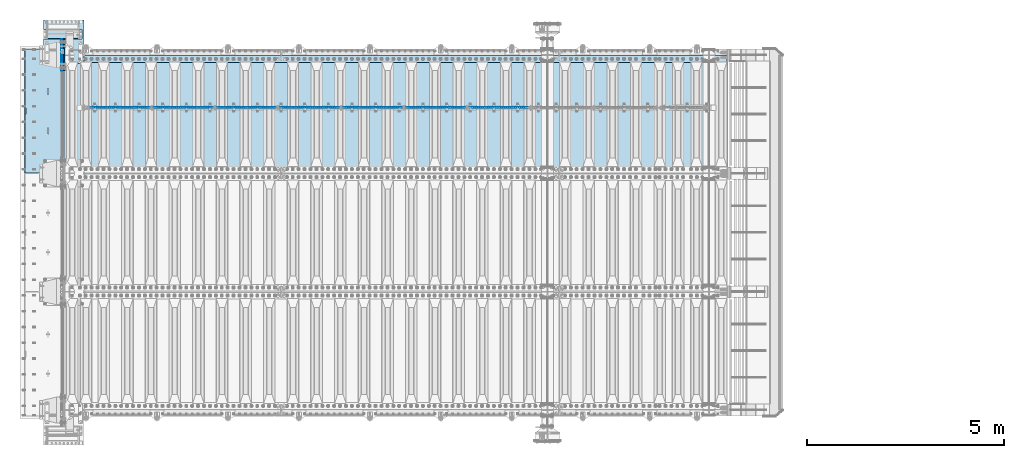
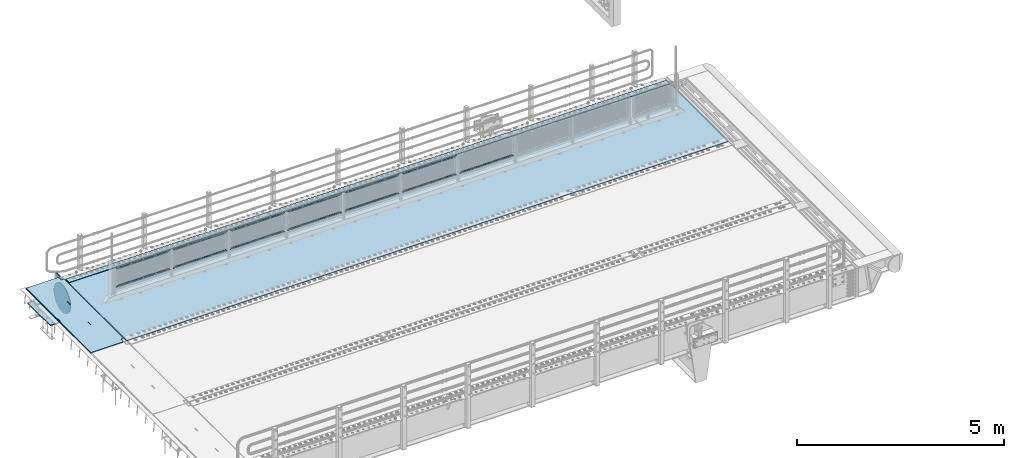
# One storey, part 194 of 247: 20 plates.
"""IFC2X3 building model written with IfcOpenShell, lengths in millimetres."""

from ifc_helpers import new_model, si_unit, frame, origin_with_axes, place, context, subcontext, project, spatial, faceted_brep, material, type_object, element, save


model = new_model("IFC2X3")

# Units and contexts
model_context = context("Model", 3, precision=1e-05, world=origin_with_axes())
body_context = subcontext(model_context, "Body", "Model", "MODEL_VIEW")
ifc_project = project(units=[si_unit("LENGTHUNIT", "METRE", prefix="MILLI"), si_unit("AREAUNIT", "SQUARE_METRE"), si_unit("VOLUMEUNIT", "CUBIC_METRE"), si_unit("MASSUNIT", "GRAM", prefix="KILO"), si_unit("TIMEUNIT", "SECOND"), si_unit("PLANEANGLEUNIT", "RADIAN"), si_unit("SOLIDANGLEUNIT", "STERADIAN"), si_unit("THERMODYNAMICTEMPERATUREUNIT", "DEGREE_CELSIUS"), si_unit("LUMINOUSINTENSITYUNIT", "LUMEN")], contexts=[model_context])

# Site, building, storey
site_placement = place(None, origin_with_axes())
site = spatial("IfcSite", under=ifc_project, at=site_placement, CompositionType="ELEMENT")
building_placement = place(site_placement, origin_with_axes())
building = spatial("IfcBuilding", under=site, at=building_placement, Name="Standard", CompositionType="ELEMENT")
storey_placement = place(building_placement, origin_with_axes())
storey = spatial("IfcBuildingStorey", under=building, at=storey_placement, Name="Undefined", CompositionType="ELEMENT", Elevation=0.0)

# Plates
ifc_material_1 = material(Name="STEEL/S355N")
plate_type_1 = type_object("IfcPlateType", PredefinedType="NOTDEFINED")
plate_1_placement = place(storey_placement, frame((-5.0037545708802, 9149.99992612933, -0.984391683369127), z_axis=(1.00000000012752e-09, -0.999999999987744, -4.95099999993936e-06), x_axis=(-0.999999999879068, -1.00000022172504e-09, -1.55519999981193e-05)))
element("IfcPlate", 1, at=plate_1_placement, inside=storey, type_object=plate_type_1, material=ifc_material_1, context=body_context, shape_type="Brep", body=[
    faceted_brep([(14.9998601691701, 15.0, 125.000024820866), (-0.000294611402138933, -0.00080690296905217, 124.999936248667), (-0.00191941583158695, 0.000806844427329922, 3020.00000492307), (14.9966216875132, 15.0, 3020.00007976655), (999.996459960937, 5.0, 1.36424205265939e-12), (984.996459960937, 15.0, 1.36424205265939e-12), (984.996459718778, 15.0, 3145.0), (999.996459718778, 5.0, 3145.0), (984.996459961366, -15.0, 1.81898940354586e-12), (999.996459960937, -4.99999999999999, 1.81898940354586e-12), (999.996459718778, -4.99999999999999, 3145.0), (984.996459719206, -15.0, 3145.0), (394.996621833771, -15.0000000044172, 1137.49999999819), (394.996621833771, 15.0, 1137.49999999819), (395.486056670582, 15.0, 1140.59016994194), (395.486056670582, -15.0000000044093, 1140.59016994194), (396.906451889569, 15.0, 1143.37785252112), (396.906451889569, -15.0000000043835, 1143.37785252112), (399.118769310224, 15.0, 1145.59016994194), (399.118769310224, -15.0000000043424, 1145.59016994194), (401.90645188929, 15.0, 1147.01056516114), (401.90645188929, -15.00000000429, 1147.01056516114), (404.996621832993, 15.0, 1147.49999999819), (404.996621832993, -15.0000000042314, 1147.49999999819), (408.086791776782, 15.0, 1147.01056516114), (408.086791776782, -15.0000000041723, 1147.01056516114), (410.874474356068, 15.0, 1145.59016994194), (410.874474356068, -15.0000000041186, 1145.59016994194), (413.086791777063, 15.0, 1143.37785252111), (413.086791777063, -15.0000000040755, 1143.37785252111), (414.507186996479, 15.0, 1140.59016994194), (414.507186996479, -15.0000000040472, 1140.59016994194), (414.996621833763, 15.0, 1137.49999999818), (414.996621833763, -15.0000000040365, 1137.49999999818), (414.996621843667, 15.0, 1007.49999999818), (414.996621843667, -15.000000003978, 1007.49999999818), (414.507187006854, 15.0, 1004.40983005444), (414.507187006854, -15.000000003986, 1004.40983005444), (413.086791787866, 15.0, 1001.62214747526), (413.086791787866, -15.0000000040118, 1001.62214747526), (410.874474367212, 15.0, 999.409830054441), (410.874474367212, -15.0000000040529, 999.409830054441), (408.086791788147, 15.0, 997.989434835241), (408.086791788147, -15.0000000041053, 997.989434835241), (404.996621844551, 15.0, 997.499999998192), (404.996621844551, -15.0000000041639, 997.499999998193), (401.906451900764, 15.0, 997.989434835241), (401.906451900764, -15.000000004223, 997.989434835241), (399.118769321479, 15.0, 999.409830054443), (399.118769321479, -15.0000000042767, 999.409830054443), (396.906451900484, 15.0, 1001.62214747527), (396.906451900484, -15.0000000043198, 1001.62214747527), (395.486056681068, 15.0, 1004.40983005444), (395.486056681068, -15.0000000043481, 1004.40983005444), (394.996621843781, 15.0, 1007.49999999819), (394.996621843781, -15.0000000043588, 1007.49999999819), (-0.000449375328786417, -14.9999999951864, 124.99986141778), (-0.000460362207132192, -15.00000004538, 3019.99993008594), (75.0001087165527, 15.0, 125.000079754137), (74.9996421865538, -15.0000000127077, 124.999930084138), (74.9997820614451, -15.0, 4.54747350886464e-13), (75.0002485914438, 15.0, 0.0), (74.9967306508662, 15.0, 3145.0), (74.9962640908673, -15.0, 3145.0), (74.9968705257564, 15.0, 3020.00007982415), (74.9964039657577, -15.0, 3019.99993015415), (960.486056642574, -15.0, 1504.4098300542), (960.486056642574, 15.0, 1504.4098300542), (959.996621805288, 15.0, 1507.49999999795), (959.996621805288, -15.0, 1507.49999999795), (961.906451861991, -15.0, 1501.62214747502), (961.906451861991, 15.0, 1501.62214747502), (964.118769282986, -15.0, 1499.4098300542), (964.118769282986, 15.0, 1499.4098300542), (966.906451862271, -15.0, 1497.98943483499), (966.906451862271, 15.0, 1497.98943483499), (969.996621806058, -15.0, 1497.49999999795), (969.996621806058, 15.0, 1497.49999999795), (973.086791749653, -15.0, 1497.98943483499), (973.086791749654, 15.0, 1497.98943483499), (975.874474328718, -15.0, 1499.40983005419), (975.874474328718, 15.0, 1499.40983005419), (978.086791749372, -15.0, 1501.62214747502), (978.086791749372, 15.0, 1501.62214747502), (979.507186968361, -15.0, 1504.40983005419), (979.507186968361, 15.0, 1504.40983005419), (979.996621805173, -15.0, 1507.49999999794), (979.996621805173, 15.0, 1507.49999999794), (979.99662179527, -15.0, 1637.49999999794), (979.99662179527, 15.0, 1637.49999999794), (979.507186957986, -15.0, 1640.59016994169), (979.507186957985, 15.0, 1640.59016994169), (978.08679173857, -15.0, 1643.37785252087), (978.08679173857, 15.0, 1643.37785252087), (975.874474317574, -15.0, 1645.59016994169), (975.874474317574, 15.0, 1645.59016994169), (973.086791738289, -15.0, 1647.0105651609), (973.086791738289, 15.0, 1647.0105651609), (969.9966217945, -15.0, 1647.49999999795), (969.9966217945, 15.0, 1647.49999999795), (966.906451850796, -15.0, 1647.0105651609), (966.906451850796, 15.0, 1647.0105651609), (964.11876927173, -15.0, 1645.5901699417), (964.11876927173, 15.0, 1645.5901699417), (961.906451851076, -15.0, 1643.37785252087), (961.906451851076, 15.0, 1643.37785252087), (960.486056632089, -15.0, 1640.5901699417), (960.486056632089, 15.0, 1640.5901699417), (959.996621795278, -15.0, 1637.49999999795), (959.996621795278, 15.0, 1637.49999999795), (395.486056593587, -15.0, 2140.59016994146), (396.906451812575, -15.0, 2143.37785252064), (399.118769233229, -15.0, 2145.59016994146), (401.906451812295, -15.0, 2147.01056516066), (404.996621755999, -15.0, 2147.49999999771), (408.086791699787, -15.0, 2147.01056516066), (410.874474279073, -15.0, 2145.59016994146), (413.086791700068, -15.0, 2143.37785252063), (414.507186919484, -15.0, 2140.59016994145), (414.996621756769, -15.0, 2137.4999999977), (414.996621766672, -15.0, 2007.4999999977), (414.50718692986, -15.0, 2004.40983005396), (413.086791710871, -15.0, 2001.62214747478), (410.874474290217, -15.0, 1999.40983005396), (408.086791711153, -15.0, 1997.98943483476), (404.996621767557, -15.0, 1997.49999999771), (401.90645182377, -15.0, 1997.98943483476), (399.118769244485, -15.0, 1999.40983005396), (396.90645182349, -15.0, 2001.62214747479), (395.486056604073, -15.0, 2004.40983005396), (394.996621766787, -15.0, 2007.49999999771), (394.996621756777, -15.0, 2137.49999999771), (396.90645182349, 15.0, 2001.62214747479), (395.486056604073, 15.0, 2004.40983005396), (399.118769244485, 15.0, 1999.40983005396), (401.90645182377, 15.0, 1997.98943483476), (404.996621767557, 15.0, 1997.49999999771), (408.086791711153, 15.0, 1997.98943483476), (410.874474290217, 15.0, 1999.40983005396), (413.086791710871, 15.0, 2001.62214747478), (414.50718692986, 15.0, 2004.40983005396), (414.996621766672, 15.0, 2007.4999999977), (414.996621756769, 15.0, 2137.4999999977), (414.507186919484, 15.0, 2140.59016994145), (413.086791700068, 15.0, 2143.37785252063), (410.874474279073, 15.0, 2145.59016994146), (408.086791699787, 15.0, 2147.01056516066), (404.996621755999, 15.0, 2147.49999999771), (401.906451812295, 15.0, 2147.01056516066), (399.118769233229, 15.0, 2145.59016994146), (396.906451812575, 15.0, 2143.37785252064), (395.486056593587, 15.0, 2140.59016994146), (394.996621756777, 15.0, 2137.49999999771), (394.996621766787, 15.0, 2007.49999999771)], [[[0, 1, 2, 3]], [[4, 5, 6, 7]], [[8, 9, 10, 11]], [[12, 13, 14, 15]], [[15, 14, 16, 17]], [[17, 16, 18, 19]], [[19, 18, 20, 21]], [[21, 20, 22, 23]], [[23, 22, 24, 25]], [[25, 24, 26, 27]], [[27, 26, 28, 29]], [[29, 28, 30, 31]], [[31, 30, 32, 33]], [[33, 32, 34, 35]], [[35, 34, 36, 37]], [[37, 36, 38, 39]], [[39, 38, 40, 41]], [[41, 40, 42, 43]], [[43, 42, 44, 45]], [[45, 44, 46, 47]], [[47, 46, 48, 49]], [[49, 48, 50, 51]], [[51, 50, 52, 53]], [[53, 52, 54, 55]], [[55, 54, 13, 12]], [[56, 57, 2, 1]], [[58, 59, 56, 1, 0]], [[60, 59, 58, 61]], [[9, 8, 60, 61, 5, 4]], [[10, 9, 4, 7]], [[62, 63, 11, 10, 7, 6]], [[63, 62, 64, 65]], [[57, 65, 64, 3, 2]], [[66, 67, 68, 69]], [[70, 71, 67, 66]], [[72, 73, 71, 70]], [[74, 75, 73, 72]], [[76, 77, 75, 74]], [[78, 79, 77, 76]], [[80, 81, 79, 78]], [[82, 83, 81, 80]], [[84, 85, 83, 82]], [[86, 87, 85, 84]], [[88, 89, 87, 86]], [[90, 91, 89, 88]], [[92, 93, 91, 90]], [[94, 95, 93, 92]], [[96, 97, 95, 94]], [[98, 99, 97, 96]], [[100, 101, 99, 98]], [[102, 103, 101, 100]], [[104, 105, 103, 102]], [[106, 107, 105, 104]], [[108, 109, 107, 106]], [[69, 68, 109, 108]], [[63, 65, 57, 56, 59, 60, 8, 11], [15, 17, 19, 21, 23, 25, 27, 29, 31, 33, 35, 37, 39, 41, 43, 45, 47, 49, 51, 53, 55, 12], [110, 111, 112, 113, 114, 115, 116, 117, 118, 119, 120, 121, 122, 123, 124, 125, 126, 127, 128, 129, 130, 131], [106, 104, 102, 100, 98, 96, 94, 92, 90, 88, 86, 84, 82, 80, 78, 76, 74, 72, 70, 66, 69, 108]], [[128, 132, 133, 129]], [[127, 134, 132, 128]], [[126, 135, 134, 127]], [[125, 136, 135, 126]], [[124, 137, 136, 125]], [[123, 138, 137, 124]], [[122, 139, 138, 123]], [[121, 140, 139, 122]], [[120, 141, 140, 121]], [[119, 142, 141, 120]], [[118, 143, 142, 119]], [[117, 144, 143, 118]], [[116, 145, 144, 117]], [[115, 146, 145, 116]], [[114, 147, 146, 115]], [[113, 148, 147, 114]], [[112, 149, 148, 113]], [[111, 150, 149, 112]], [[110, 151, 150, 111]], [[131, 152, 151, 110]], [[130, 153, 152, 131]], [[129, 133, 153, 130]], [[64, 62, 6, 5, 61, 58, 0, 3], [50, 48, 46, 44, 42, 40, 38, 36, 34, 32, 30, 28, 26, 24, 22, 20, 18, 16, 14, 13, 54, 52], [132, 134, 135, 136, 137, 138, 139, 140, 141, 142, 143, 144, 145, 146, 147, 148, 149, 150, 151, 152, 153, 133], [71, 73, 75, 77, 79, 81, 83, 85, 87, 89, 91, 93, 95, 97, 99, 101, 103, 105, 107, 109, 68, 67]]]),
])
ifc_material_2 = material()
plate_type_2 = type_object("IfcPlateType", PredefinedType="NOTDEFINED")
plate_2_placement = place(storey_placement, frame((454.999999694879, 9645.00000169461, -803.000000000004), z_axis=(0.0, -0.999999999999548, -9.5100000000016e-07), x_axis=(-1.0, 0.0, 0.0)))
element("IfcPlate", 2, at=plate_2_placement, inside=storey, type_object=plate_type_2, material=ifc_material_2, context=body_context, shape_type="Brep", body=[
    faceted_brep([(0.0, 0.0, 235.0), (0.0, -15.0, 220.0), (979.0, -15.0, 220.0), (979.0, 0.0, 235.0), (0.0, 15.0, 235.0), (0.0, 15.0, 0.0), (0.0, -15.0, 0.0), (979.0, 15.0, 235.0), (979.0, -15.0, 0.0), (979.0, 15.0, 0.0)], [[[0, 1, 2, 3]], [[4, 5, 6, 1, 0]], [[7, 4, 0, 3]], [[8, 9, 7, 3, 2]], [[8, 6, 5, 9]], [[7, 9, 5, 4]], [[6, 8, 2, 1]]]),
])
plate_type_3 = type_object("IfcPlateType", PredefinedType="NOTDEFINED")
plate_3_placement = place(storey_placement, frame((-524.000000550232, 9890.00000071562, -1043.0), z_axis=(1.0, 0.0, 0.0), x_axis=(0.0, -0.999999999999548, -9.5100000000016e-07)))
element("IfcPlate", 3, at=plate_3_placement, inside=storey, type_object=plate_type_3, material=ifc_material_2, context=body_context, shape_type="Brep", body=[
    faceted_brep([(0.0, -15.0, 0.0), (2.93249286187347e-06, -15.0, 1025.0), (2.93249286187347e-06, 15.0, 1025.0), (0.0, 15.0, 0.0), (1100.0, -15.0, 1025.0), (1100.0, 15.0, 1025.0), (1100.0, -15.0, -1.9554136088118e-11), (1100.0, 15.0, -1.9554136088118e-11)], [[[0, 1, 2, 3]], [[1, 4, 5, 2]], [[4, 6, 7, 5]], [[6, 0, 3, 7]], [[5, 7, 3, 2]], [[6, 4, 1, 0]]]),
])
ifc_material_3 = material(Name="Misc_Undefined")
plate_type_4 = type_object("IfcPlateType", PredefinedType="NOTDEFINED")
for number, where, z_axis, x_axis in (
    (4, (10274.5050117304, 7670.5, 351.520303374641), (0.0, 0.0, 1.0), (1.0, 0.0, 0.0)),
    (5, (8674.50501173036, 7670.5, 351.520303374641), (0.0, 0.0, 1.0), (1.0, 0.0, 0.0)),
):
    element("IfcPlate", number, at=place(storey_placement, frame(where, z_axis=z_axis, x_axis=x_axis)), inside=storey, type_object=plate_type_4, material=ifc_material_3, context=body_context, shape_type="Brep", body=[
        faceted_brep([(1.81898940354586e-12, -1.5, -5.6843418860808e-14), (35.0002975463885, -1.5, 34.9996948242187), (35.0002975463885, 1.5, 34.9996948242187), (1.81898940354586e-12, 1.5, -5.6843418860808e-14), (1457.99035644531, -1.5, 34.9999923706055), (1457.99035644531, 1.5, 34.9999923706055), (1492.98999023438, -1.5, -2.87985812974512e-09), (1492.98999023438, 1.5, -2.87985812974512e-09)], [[[0, 1, 2, 3]], [[1, 4, 5, 2]], [[4, 6, 7, 5]], [[6, 0, 3, 7]], [[5, 7, 3, 2]], [[6, 4, 1, 0]]]),
    ])
plate_4_placement = place(storey_placement, frame((10167.5000001876, 7670.5, 914.520000175701), z_axis=(-0.707103624179499, 0.0, 0.707109938179501), x_axis=(-0.707109938179502, 0.0, -0.707103624179498)))
element("IfcPlate", 6, at=plate_4_placement, inside=storey, type_object=plate_type_4, material=ifc_material_3, context=body_context, shape_type="Brep", body=[
    faceted_brep([(1.81898940354586e-12, -1.5, -5.6843418860808e-14), (1055.71520996094, -1.5, 1055.70581054688), (1055.71520996094, 1.5, 1055.70581054688), (1.81898940354586e-12, 1.5, -5.6843418860808e-14), (1055.70812988281, -1.5, 1006.20135498047), (1055.70812988281, 1.5, 1006.20135498047), (49.4976959228497, -1.5, 7.09405867382884e-11), (49.4976959228497, 1.5, 7.09405867382884e-11)], [[[0, 1, 2, 3]], [[1, 4, 5, 2]], [[4, 6, 7, 5]], [[6, 0, 3, 7]], [[5, 7, 3, 2]], [[6, 4, 1, 0]]]),
])
plate_5_placement = place(storey_placement, frame((7074.50501173036, 7670.5, 351.520303374641), z_axis=(0.0, 0.0, 1.0), x_axis=(1.0, 0.0, 0.0)))
element("IfcPlate", 7, at=plate_5_placement, inside=storey, type_object=plate_type_4, material=ifc_material_3, context=body_context, shape_type="Brep", body=[
    faceted_brep([(1.81898940354586e-12, -1.5, -5.6843418860808e-14), (35.0002975463885, -1.5, 34.9996948242187), (35.0002975463885, 1.5, 34.9996948242187), (1.81898940354586e-12, 1.5, -5.6843418860808e-14), (1457.99035644531, -1.5, 34.9999923706055), (1457.99035644531, 1.5, 34.9999923706055), (1492.98999023438, -1.5, -2.87985812974512e-09), (1492.98999023438, 1.5, -2.87985812974512e-09)], [[[0, 1, 2, 3]], [[1, 4, 5, 2]], [[4, 6, 7, 5]], [[6, 0, 3, 7]], [[5, 7, 3, 2]], [[6, 4, 1, 0]]]),
])
plate_6_placement = place(storey_placement, frame((8567.5000001876, 7670.5, 914.520000175701), z_axis=(-0.707103624179499, 0.0, 0.707109938179501), x_axis=(-0.707109938179502, 0.0, -0.707103624179498)))
element("IfcPlate", 8, at=plate_6_placement, inside=storey, type_object=plate_type_4, material=ifc_material_3, context=body_context, shape_type="Brep", body=[
    faceted_brep([(1.81898940354586e-12, -1.5, -5.6843418860808e-14), (1055.71520996094, -1.5, 1055.70581054688), (1055.71520996094, 1.5, 1055.70581054688), (1.81898940354586e-12, 1.5, -5.6843418860808e-14), (1055.70812988281, -1.5, 1006.20135498047), (1055.70812988281, 1.5, 1006.20135498047), (49.4976959228497, -1.5, 7.09405867382884e-11), (49.4976959228497, 1.5, 7.09405867382884e-11)], [[[0, 1, 2, 3]], [[1, 4, 5, 2]], [[4, 6, 7, 5]], [[6, 0, 3, 7]], [[5, 7, 3, 2]], [[6, 4, 1, 0]]]),
])
plate_7_placement = place(storey_placement, frame((5474.50501173036, 7670.5, 351.520303374641), z_axis=(0.0, 0.0, 1.0), x_axis=(1.0, 0.0, 0.0)))
element("IfcPlate", 9, at=plate_7_placement, inside=storey, type_object=plate_type_4, material=ifc_material_3, context=body_context, shape_type="Brep", body=[
    faceted_brep([(1.81898940354586e-12, -1.5, -5.6843418860808e-14), (35.0002975463885, -1.5, 34.9996948242187), (35.0002975463885, 1.5, 34.9996948242187), (1.81898940354586e-12, 1.5, -5.6843418860808e-14), (1457.99035644531, -1.5, 34.9999923706055), (1457.99035644531, 1.5, 34.9999923706055), (1492.98999023438, -1.5, -2.87985812974512e-09), (1492.98999023438, 1.5, -2.87985812974512e-09)], [[[0, 1, 2, 3]], [[1, 4, 5, 2]], [[4, 6, 7, 5]], [[6, 0, 3, 7]], [[5, 7, 3, 2]], [[6, 4, 1, 0]]]),
])
plate_8_placement = place(storey_placement, frame((6967.5000001876, 7670.5, 914.520000175701), z_axis=(-0.707103624179499, 0.0, 0.707109938179501), x_axis=(-0.707109938179502, 0.0, -0.707103624179498)))
element("IfcPlate", 10, at=plate_8_placement, inside=storey, type_object=plate_type_4, material=ifc_material_3, context=body_context, shape_type="Brep", body=[
    faceted_brep([(1.81898940354586e-12, -1.5, -5.6843418860808e-14), (1055.71520996094, -1.5, 1055.70581054688), (1055.71520996094, 1.5, 1055.70581054688), (1.81898940354586e-12, 1.5, -5.6843418860808e-14), (1055.70812988281, -1.5, 1006.20135498047), (1055.70812988281, 1.5, 1006.20135498047), (49.4976959228497, -1.5, 7.09405867382884e-11), (49.4976959228497, 1.5, 7.09405867382884e-11)], [[[0, 1, 2, 3]], [[1, 4, 5, 2]], [[4, 6, 7, 5]], [[6, 0, 3, 7]], [[5, 7, 3, 2]], [[6, 4, 1, 0]]]),
])
plate_9_placement = place(storey_placement, frame((3874.50501173036, 7670.5, 351.520303374641), z_axis=(0.0, 0.0, 1.0), x_axis=(1.0, 0.0, 0.0)))
element("IfcPlate", 11, at=plate_9_placement, inside=storey, type_object=plate_type_4, material=ifc_material_3, context=body_context, shape_type="Brep", body=[
    faceted_brep([(1.81898940354586e-12, -1.5, -5.6843418860808e-14), (35.0002975463885, -1.5, 34.9996948242187), (35.0002975463885, 1.5, 34.9996948242187), (1.81898940354586e-12, 1.5, -5.6843418860808e-14), (1457.99035644531, -1.5, 34.9999923706055), (1457.99035644531, 1.5, 34.9999923706055), (1492.98999023438, -1.5, -2.87985812974512e-09), (1492.98999023438, 1.5, -2.87985812974512e-09)], [[[0, 1, 2, 3]], [[1, 4, 5, 2]], [[4, 6, 7, 5]], [[6, 0, 3, 7]], [[5, 7, 3, 2]], [[6, 4, 1, 0]]]),
])
plate_10_placement = place(storey_placement, frame((5367.5000001876, 7670.5, 914.520000175701), z_axis=(-0.707103624179499, 0.0, 0.707109938179501), x_axis=(-0.707109938179502, 0.0, -0.707103624179498)))
element("IfcPlate", 12, at=plate_10_placement, inside=storey, type_object=plate_type_4, material=ifc_material_3, context=body_context, shape_type="Brep", body=[
    faceted_brep([(1.81898940354586e-12, -1.5, -5.6843418860808e-14), (1055.71520996094, -1.5, 1055.70581054688), (1055.71520996094, 1.5, 1055.70581054688), (1.81898940354586e-12, 1.5, -5.6843418860808e-14), (1055.70812988281, -1.5, 1006.20135498047), (1055.70812988281, 1.5, 1006.20135498047), (49.4976959228497, -1.5, 7.09405867382884e-11), (49.4976959228497, 1.5, 7.09405867382884e-11)], [[[0, 1, 2, 3]], [[1, 4, 5, 2]], [[4, 6, 7, 5]], [[6, 0, 3, 7]], [[5, 7, 3, 2]], [[6, 4, 1, 0]]]),
])
plate_11_placement = place(storey_placement, frame((2274.50501173036, 7670.5, 351.520303374641), z_axis=(0.0, 0.0, 1.0), x_axis=(1.0, 0.0, 0.0)))
element("IfcPlate", 13, at=plate_11_placement, inside=storey, type_object=plate_type_4, material=ifc_material_3, context=body_context, shape_type="Brep", body=[
    faceted_brep([(1.81898940354586e-12, -1.5, -5.6843418860808e-14), (35.0002975463885, -1.5, 34.9996948242187), (35.0002975463885, 1.5, 34.9996948242187), (1.81898940354586e-12, 1.5, -5.6843418860808e-14), (1457.99035644531, -1.5, 34.9999923706055), (1457.99035644531, 1.5, 34.9999923706055), (1492.98999023438, -1.5, -2.87985812974512e-09), (1492.98999023438, 1.5, -2.87985812974512e-09)], [[[0, 1, 2, 3]], [[1, 4, 5, 2]], [[4, 6, 7, 5]], [[6, 0, 3, 7]], [[5, 7, 3, 2]], [[6, 4, 1, 0]]]),
])
plate_12_placement = place(storey_placement, frame((3767.5000001876, 7670.5, 914.520000175701), z_axis=(-0.707103624179499, 0.0, 0.707109938179501), x_axis=(-0.707109938179502, 0.0, -0.707103624179498)))
element("IfcPlate", 14, at=plate_12_placement, inside=storey, type_object=plate_type_4, material=ifc_material_3, context=body_context, shape_type="Brep", body=[
    faceted_brep([(1.81898940354586e-12, -1.5, -5.6843418860808e-14), (1055.71520996094, -1.5, 1055.70581054688), (1055.71520996094, 1.5, 1055.70581054688), (1.81898940354586e-12, 1.5, -5.6843418860808e-14), (1055.70812988281, -1.5, 1006.20135498047), (1055.70812988281, 1.5, 1006.20135498047), (49.4976959228497, -1.5, 7.09405867382884e-11), (49.4976959228497, 1.5, 7.09405867382884e-11)], [[[0, 1, 2, 3]], [[1, 4, 5, 2]], [[4, 6, 7, 5]], [[6, 0, 3, 7]], [[5, 7, 3, 2]], [[6, 4, 1, 0]]]),
])
plate_13_placement = place(storey_placement, frame((674.505011730362, 7670.5, 351.520303374641), z_axis=(0.0, 0.0, 1.0), x_axis=(1.0, 0.0, 0.0)))
element("IfcPlate", 15, at=plate_13_placement, inside=storey, type_object=plate_type_4, material=ifc_material_3, context=body_context, shape_type="Brep", body=[
    faceted_brep([(1.81898940354586e-12, -1.5, -5.6843418860808e-14), (35.0002975463885, -1.5, 34.9996948242187), (35.0002975463885, 1.5, 34.9996948242187), (1.81898940354586e-12, 1.5, -5.6843418860808e-14), (1457.99035644531, -1.5, 34.9999923706055), (1457.99035644531, 1.5, 34.9999923706055), (1492.98999023438, -1.5, -2.87985812974512e-09), (1492.98999023438, 1.5, -2.87985812974512e-09)], [[[0, 1, 2, 3]], [[1, 4, 5, 2]], [[4, 6, 7, 5]], [[6, 0, 3, 7]], [[5, 7, 3, 2]], [[6, 4, 1, 0]]]),
])
plate_14_placement = place(storey_placement, frame((2167.5000001876, 7670.5, 914.520000175701), z_axis=(-0.707103624179499, 0.0, 0.707109938179501), x_axis=(-0.707109938179502, 0.0, -0.707103624179498)))
element("IfcPlate", 16, at=plate_14_placement, inside=storey, type_object=plate_type_4, material=ifc_material_3, context=body_context, shape_type="Brep", body=[
    faceted_brep([(1.81898940354586e-12, -1.5, -5.6843418860808e-14), (1055.71520996094, -1.5, 1055.70581054688), (1055.71520996094, 1.5, 1055.70581054688), (1.81898940354586e-12, 1.5, -5.6843418860808e-14), (1055.70812988281, -1.5, 1006.20135498047), (1055.70812988281, 1.5, 1006.20135498047), (49.4976959228497, -1.5, 7.09405867382884e-11), (49.4976959228497, 1.5, 7.09405867382884e-11)], [[[0, 1, 2, 3]], [[1, 4, 5, 2]], [[4, 6, 7, 5]], [[6, 0, 3, 7]], [[5, 7, 3, 2]], [[6, 4, 1, 0]]]),
])
plate_type_5 = type_object("IfcPlateType", PredefinedType="NOTDEFINED")
plate_15_placement = place(storey_placement, frame((-5.0, 8600.0, -20.0), z_axis=(0.0, 1.0, 0.0), x_axis=(0.0, 0.0, -1.0)))
element("IfcPlate", 17, at=plate_15_placement, inside=storey, type_object=plate_type_5, material=ifc_material_1, context=body_context, shape_type="Brep", body=[
    faceted_brep([(855.0, -15.0, 572.963114671537), (855.0, 15.0, 572.963114671537), (849.182410261294, 15.0, 585.889268817531), (849.182410261294, -15.0, 585.889268817531), (824.193546357474, 15.0, 627.225898692485), (824.193546357474, -15.0, 627.225898692485), (794.404299268454, 15.0, 665.249063296341), (794.404299268454, -15.0, 665.249063296341), (760.249063296334, 15.0, 699.404299268464), (760.249063296334, -15.0, 699.404299268464), (722.22589869248, 15.0, 729.193546357486), (722.22589869248, -15.0, 729.193546357486), (680.889268817528, 15.0, 754.182410261309), (680.889268817528, -15.0, 754.182410261309), (636.841954817037, 15.0, 774.006497074193), (636.841954817037, -15.0, 774.006497074193), (590.726265715048, 15.0, 788.37672697045), (590.726265715048, -15.0, 788.37672697045), (543.214672102156, 15.0, 797.083549639254), (543.214672102156, -15.0, 797.083549639254), (495.0, -15.0, 800.000000000029), (495.0, 15.0, 800.0), (494.999999999412, -15.0, 0.0), (494.999999999412, 15.0, 0.0), (543.214672102129, 15.0, 2.91645036080718), (543.214672102129, -15.0, 2.91645036080718), (590.726265715023, 15.0, 11.6232730296083), (590.726265715023, -15.0, 11.6232730296083), (636.841954817014, 15.0, 25.9935029258631), (636.841954817014, -15.0, 25.9935029258631), (680.889268817507, 15.0, 45.817589738745), (680.889268817507, -15.0, 45.817589738745), (722.225898692462, 15.0, 70.8064536425663), (722.225898692462, -15.0, 70.8064536425663), (760.249063296318, 15.0, 100.595700731589), (760.249063296318, -15.0, 100.595700731589), (794.404299268441, 15.0, 134.750936703711), (794.404299268441, -15.0, 134.750936703711), (824.193546357463, 15.0, 172.774101307567), (824.193546357463, -15.0, 172.774101307567), (849.182410261284, 15.0, 214.110731182522), (849.182410261284, -15.0, 214.110731182522), (855.0, -15.0, 227.036885328536), (855.0, 15.0, 227.036885328536), (0.0, -15.0, 0.0), (0.0, 15.0, 0.0), (0.0, 15.0, 800.0), (0.0, -15.0, 800.0)], [[[0, 1, 2, 3]], [[3, 2, 4, 5]], [[5, 4, 6, 7]], [[7, 6, 8, 9]], [[9, 8, 10, 11]], [[11, 10, 12, 13]], [[13, 12, 14, 15]], [[15, 14, 16, 17]], [[17, 16, 18, 19]], [[20, 19, 18, 21]], [[22, 23, 24, 25]], [[25, 24, 26, 27]], [[27, 26, 28, 29]], [[29, 28, 30, 31]], [[31, 30, 32, 33]], [[33, 32, 34, 35]], [[35, 34, 36, 37]], [[37, 36, 38, 39]], [[39, 38, 40, 41]], [[42, 41, 40, 43]], [[42, 43, 1, 0]], [[44, 45, 23, 22]], [[16, 14, 12, 10, 8, 6, 4, 2, 1, 43, 40, 38, 36, 34, 32, 30, 28, 26, 24, 23, 45, 46, 21, 18]], [[44, 47, 46, 45]], [[46, 47, 20, 21]], [[47, 44, 22, 25, 27, 29, 31, 33, 35, 37, 39, 41, 42, 0, 3, 5, 7, 9, 11, 13, 15, 17, 19, 20]]]),
])
ifc_material_4 = material(Name="STEEL/S235JR")
plate_type_6 = type_object("IfcPlateType", PredefinedType="NOTDEFINED")
plate_16_placement = place(storey_placement, frame((16807.0, 8815.0, 20.0), z_axis=(-1.0, 0.0, 0.0), x_axis=(0.0, 1.0, 0.0)))
element("IfcPlate", 18, at=plate_16_placement, inside=storey, type_object=plate_type_6, material=ifc_material_4, context=body_context, shape_type="Brep", body=[
    faceted_brep([(0.0, -6.0, 0.0), (0.0, -6.0, 16787.0), (0.0, 6.0, 16787.0), (0.0, 6.0, 0.0), (170.0, -6.0, 16787.0), (170.0, 6.0, 16787.0), (170.0, -6.0, 0.0), (170.0, 6.0, 0.0)], [[[0, 1, 2, 3]], [[1, 4, 5, 2]], [[4, 6, 7, 5]], [[6, 0, 3, 7]], [[5, 7, 3, 2]], [[6, 4, 1, 0]]]),
])
plate_type_7 = type_object("IfcPlateType", PredefinedType="NOTDEFINED")
plate_17_placement = place(storey_placement, frame((10.0, 8995.0, 7.0), z_axis=(1.0, 0.0, 0.0), x_axis=(0.0, -0.999999999999548, -9.5100000000016e-07)))
element("IfcPlate", 19, at=plate_17_placement, inside=storey, type_object=plate_type_7, material=ifc_material_1, context=body_context, shape_type="Brep", body=[
    faceted_brep([(0.0, -7.0, 0.0), (-2.96859070658684e-09, -7.0, 16807.0), (-2.96859070658684e-09, 7.0, 16807.0), (0.0, 7.0, 0.0), (2990.0, -7.0, 16807.0), (2990.0, 7.0, 16807.0), (2990.0, -7.0, 0.0), (2990.0, 7.0, 0.0)], [[[0, 1, 2, 3]], [[1, 4, 5, 2]], [[4, 6, 7, 5]], [[6, 0, 3, 7]], [[5, 7, 3, 2]], [[6, 4, 1, 0]]]),
])
plate_type_8 = type_object("IfcPlateType", PredefinedType="NOTDEFINED")
plate_18_placement = place(storey_placement, frame((-62.5000000000001, 9400.0, -114.999999999998), z_axis=(0.0, 0.0, -1.0), x_axis=(0.0, -0.999999999999548, -9.5100000000016e-07)))
element("IfcPlate", 20, at=plate_18_placement, inside=storey, type_object=plate_type_8, material=ifc_material_1, context=body_context, shape_type="Brep", body=[
    faceted_brep([(0.0, -12.5, 400.0), (2.91645036077898, -12.5, 448.214672102129), (2.91645036077898, 12.5, 448.214672102129), (0.0, 12.5, 400.0), (11.6232730295797, -12.5, 495.726265715023), (11.6232730295797, 12.5, 495.726265715023), (25.993502925834, -12.5, 541.841954817014), (25.993502925834, 12.5, 541.841954817014), (45.8175897387155, -12.5, 585.889268817507), (45.8175897387155, 12.5, 585.889268817507), (70.8064536425372, -12.5, 627.225898692462), (70.8064536425372, 12.5, 627.225898692462), (100.595700731559, -12.5, 665.249063296318), (100.595700731559, 12.5, 665.249063296318), (134.750936703682, -12.5, 699.40429926844), (134.750936703682, 12.5, 699.40429926844), (172.774101307537, -12.5, 729.193546357462), (172.774101307537, 12.5, 729.193546357462), (214.110731182493, -12.5, 754.182410261284), (214.110731182493, 12.5, 754.182410261284), (258.158045182985, -12.5, 774.006497074166), (258.158045182985, 12.5, 774.006497074166), (304.273734284976, -12.5, 788.376726970421), (304.273734284976, 12.5, 788.376726970421), (351.785327897871, -12.5, 797.083549639221), (351.785327897871, 12.5, 797.083549639221), (400.0, -12.5, 800.0), (400.0, 12.5, 800.0), (448.214672102129, -12.5, 797.083549639222), (448.214672102129, 12.5, 797.083549639222), (495.726265715022, -12.5, 788.376726970421), (495.726265715022, 12.5, 788.376726970421), (541.841954817013, -12.5, 774.006497074166), (541.841954817013, 12.5, 774.006497074166), (585.889268817507, -12.5, 754.182410261284), (585.889268817507, 12.5, 754.182410261284), (627.225898692463, -12.5, 729.193546357463), (627.225898692463, 12.5, 729.193546357463), (665.249063296318, -12.5, 699.404299268441), (665.249063296318, 12.5, 699.404299268441), (699.404299268441, -12.5, 665.249063296318), (699.404299268441, 12.5, 665.249063296318), (729.193546357463, -12.5, 627.225898692462), (729.193546357463, 12.5, 627.225898692462), (754.182410261285, -12.5, 585.889268817507), (754.182410261285, 12.5, 585.889268817507), (774.006497074166, -12.5, 541.841954817014), (774.006497074166, 12.5, 541.841954817014), (788.37672697042, -12.5, 495.726265715023), (788.37672697042, 12.5, 495.726265715023), (797.083549639221, -12.5, 448.214672102129), (797.083549639221, 12.5, 448.214672102129), (800.0, -12.5, 400.0), (800.0, 12.5, 400.0), (797.083549639221, -12.5, 351.785327897871), (797.083549639221, 12.5, 351.785327897871), (788.37672697042, -12.5, 304.273734284977), (788.37672697042, 12.5, 304.273734284977), (774.006497074166, -12.5, 258.158045182986), (774.006497074166, 12.5, 258.158045182986), (754.182410261285, -12.5, 214.110731182493), (754.182410261285, 12.5, 214.110731182493), (729.193546357463, -12.5, 172.774101307538), (729.193546357463, 12.5, 172.774101307538), (699.404299268441, -12.5, 134.750936703682), (699.404299268441, 12.5, 134.750936703682), (665.249063296318, -12.5, 100.59570073156), (665.249063296318, 12.5, 100.59570073156), (627.225898692463, -12.5, 70.8064536425375), (627.225898692463, 12.5, 70.8064536425375), (585.889268817507, -12.5, 45.817589738716), (585.889268817507, 12.5, 45.817589738716), (541.841954817015, -12.5, 25.9935029258342), (541.841954817015, 12.5, 25.9935029258342), (495.726265715024, -12.5, 11.6232730295793), (495.726265715024, 12.5, 11.6232730295793), (448.214672102129, -12.5, 2.91645036077847), (448.214672102129, 12.5, 2.91645036077847), (400.0, -12.5, -5.6843418860808e-14), (400.0, 12.5, -5.6843418860808e-14), (351.785327897871, -12.5, 2.91645036077836), (351.785327897871, 12.5, 2.91645036077836), (304.273734284976, -12.5, 11.6232730295792), (304.273734284976, 12.5, 11.6232730295792), (258.158045182985, -12.5, 25.993502925834), (258.158045182985, 12.5, 25.993502925834), (214.110731182493, -12.5, 45.817589738716), (214.110731182493, 12.5, 45.817589738716), (172.774101307537, -12.5, 70.8064536425374), (172.774101307537, 12.5, 70.8064536425374), (134.750936703682, -12.5, 100.595700731559), (134.750936703682, 12.5, 100.595700731559), (100.595700731559, -12.5, 134.750936703682), (100.595700731559, 12.5, 134.750936703682), (70.8064536425372, -12.5, 172.774101307538), (70.8064536425372, 12.5, 172.774101307538), (45.8175897387155, -12.5, 214.110731182492), (45.8175897387155, 12.5, 214.110731182492), (25.993502925834, -12.5, 258.158045182986), (25.993502925834, 12.5, 258.158045182986), (11.6232730295797, -12.5, 304.273734284977), (11.6232730295797, 12.5, 304.273734284977), (2.91645036077898, -12.5, 351.785327897871), (2.91645036077898, 12.5, 351.785327897871)], [[[0, 1, 2, 3]], [[1, 4, 5, 2]], [[4, 6, 7, 5]], [[6, 8, 9, 7]], [[8, 10, 11, 9]], [[10, 12, 13, 11]], [[12, 14, 15, 13]], [[14, 16, 17, 15]], [[16, 18, 19, 17]], [[18, 20, 21, 19]], [[20, 22, 23, 21]], [[22, 24, 25, 23]], [[24, 26, 27, 25]], [[26, 28, 29, 27]], [[28, 30, 31, 29]], [[30, 32, 33, 31]], [[32, 34, 35, 33]], [[34, 36, 37, 35]], [[36, 38, 39, 37]], [[38, 40, 41, 39]], [[40, 42, 43, 41]], [[42, 44, 45, 43]], [[44, 46, 47, 45]], [[46, 48, 49, 47]], [[48, 50, 51, 49]], [[50, 52, 53, 51]], [[52, 54, 55, 53]], [[54, 56, 57, 55]], [[56, 58, 59, 57]], [[58, 60, 61, 59]], [[60, 62, 63, 61]], [[62, 64, 65, 63]], [[64, 66, 67, 65]], [[66, 68, 69, 67]], [[68, 70, 71, 69]], [[70, 72, 73, 71]], [[72, 74, 75, 73]], [[74, 76, 77, 75]], [[76, 78, 79, 77]], [[78, 80, 81, 79]], [[80, 82, 83, 81]], [[82, 84, 85, 83]], [[84, 86, 87, 85]], [[86, 88, 89, 87]], [[88, 90, 91, 89]], [[90, 92, 93, 91]], [[92, 94, 95, 93]], [[94, 96, 97, 95]], [[96, 98, 99, 97]], [[98, 100, 101, 99]], [[100, 102, 103, 101]], [[102, 0, 3, 103]], [[5, 7, 9, 11, 13, 15, 17, 19, 21, 23, 25, 27, 29, 31, 33, 35, 37, 39, 41, 43, 45, 47, 49, 51, 53, 55, 57, 59, 61, 63, 65, 67, 69, 71, 73, 75, 77, 79, 81, 83, 85, 87, 89, 91, 93, 95, 97, 99, 101, 103, 3, 2]], [[102, 100, 98, 96, 94, 92, 90, 88, 86, 84, 82, 80, 78, 76, 74, 72, 70, 68, 66, 64, 62, 60, 58, 56, 54, 52, 50, 48, 46, 44, 42, 40, 38, 36, 34, 32, 30, 28, 26, 24, 22, 20, 18, 16, 14, 12, 10, 8, 6, 4, 1, 0]]]),
])

save(model, "model.ifc")
